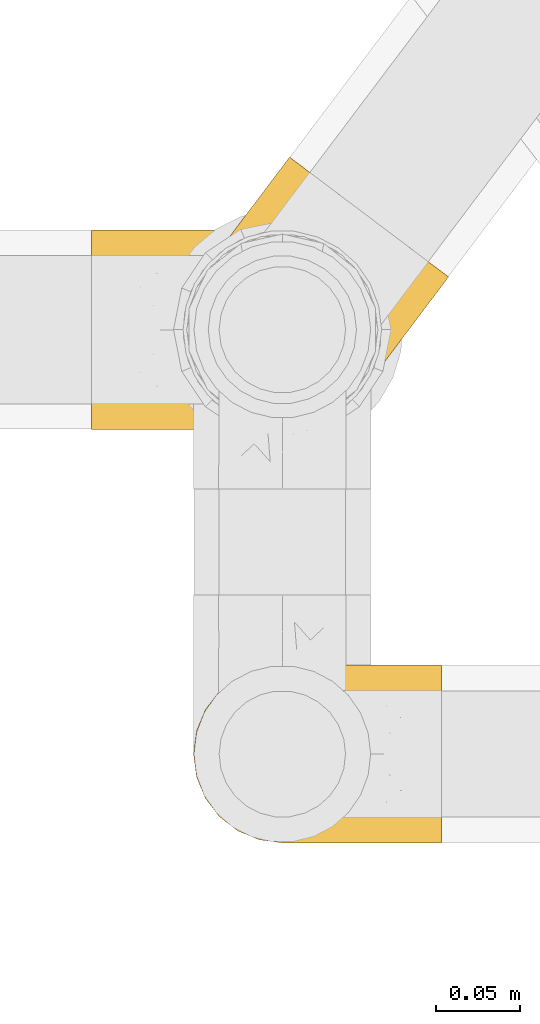
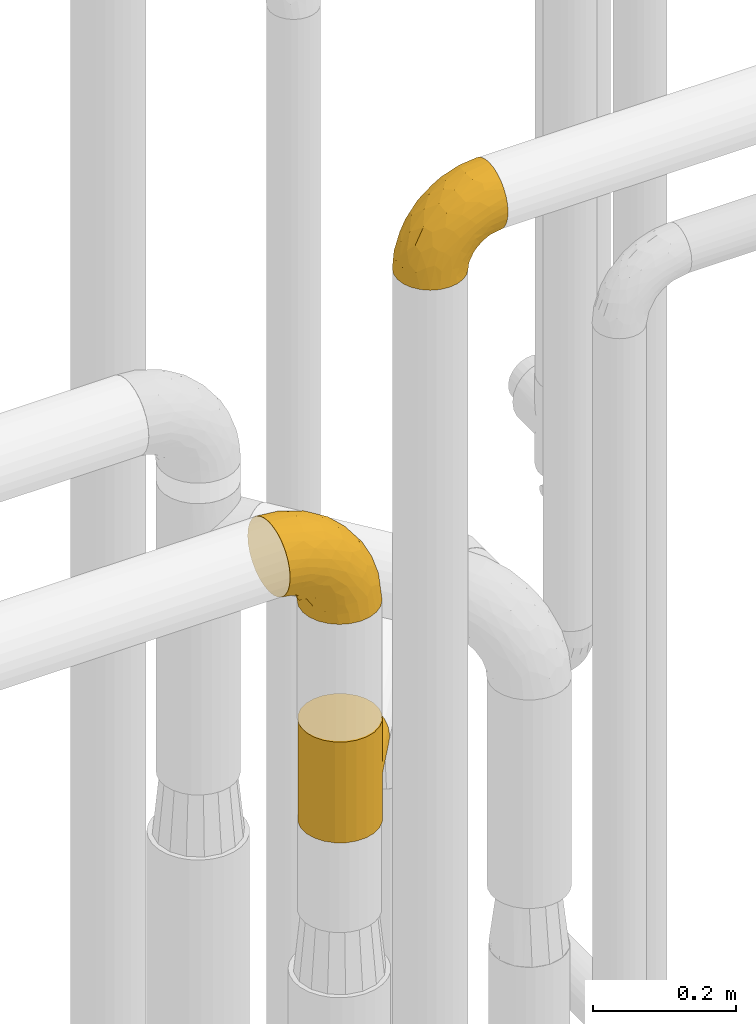
# One storey, part 378 of 827: 3 coverings.
"""IFC2X3 building model written with IfcOpenShell, lengths in millimetres."""

from ifc_helpers import new_model, entity, si_unit, converted_unit, derived_unit, direction, frame, origin, place, context, subcontext, project, spatial, faceted_brep, element, save


model = new_model("IFC2X3")

# Units and contexts
model_context = context("Model", 3, precision=0.01, world=origin(), true_north=direction((6.12303176911189e-17, 1.0)))
body_context = subcontext(model_context, "Body", "Model", "MODEL_VIEW")
ifc_project = project(units=[si_unit("LENGTHUNIT", "METRE", prefix="MILLI"), si_unit("AREAUNIT", "SQUARE_METRE"), si_unit("VOLUMEUNIT", "CUBIC_METRE"), converted_unit("PLANEANGLEUNIT", "DEGREE", entity("IfcRatioMeasure", 0.0174532925199433), si_unit("PLANEANGLEUNIT", "RADIAN"), dimensions=[0, 0, 0, 0, 0, 0, 0]), si_unit("MASSUNIT", "GRAM", prefix="KILO"), derived_unit("MASSDENSITYUNIT", [(si_unit("MASSUNIT", "GRAM", prefix="KILO"), 1), (si_unit("LENGTHUNIT", "METRE"), -3)]), derived_unit("MOMENTOFINERTIAUNIT", [(si_unit("LENGTHUNIT", "METRE"), 4)]), si_unit("TIMEUNIT", "SECOND"), si_unit("FREQUENCYUNIT", "HERTZ"), si_unit("THERMODYNAMICTEMPERATUREUNIT", "DEGREE_CELSIUS"), derived_unit("THERMALTRANSMITTANCEUNIT", [(si_unit("MASSUNIT", "GRAM", prefix="KILO"), 1), (si_unit("THERMODYNAMICTEMPERATUREUNIT", "KELVIN"), -1), (si_unit("TIMEUNIT", "SECOND"), -3)]), derived_unit("VOLUMETRICFLOWRATEUNIT", [(si_unit("LENGTHUNIT", "METRE"), 3), (si_unit("TIMEUNIT", "SECOND"), -1)]), derived_unit("MASSFLOWRATEUNIT", [(si_unit("MASSUNIT", "GRAM", prefix="KILO"), 1), (si_unit("TIMEUNIT", "SECOND"), -1)]), derived_unit("ROTATIONALFREQUENCYUNIT", [(si_unit("TIMEUNIT", "SECOND"), -1)]), si_unit("ELECTRICCURRENTUNIT", "AMPERE"), si_unit("ELECTRICVOLTAGEUNIT", "VOLT"), si_unit("POWERUNIT", "WATT"), si_unit("FORCEUNIT", "NEWTON", prefix="KILO"), si_unit("ILLUMINANCEUNIT", "LUX"), si_unit("LUMINOUSFLUXUNIT", "LUMEN"), si_unit("LUMINOUSINTENSITYUNIT", "CANDELA"), derived_unit("USERDEFINED", [(si_unit("MASSUNIT", "GRAM", prefix="KILO"), -1), (si_unit("LENGTHUNIT", "METRE"), -2), (si_unit("TIMEUNIT", "SECOND"), 3), (si_unit("LUMINOUSFLUXUNIT", "LUMEN"), 1)]), derived_unit("LINEARVELOCITYUNIT", [(si_unit("LENGTHUNIT", "METRE"), 1), (si_unit("TIMEUNIT", "SECOND"), -1)]), si_unit("PRESSUREUNIT", "PASCAL"), derived_unit("USERDEFINED", [(si_unit("LENGTHUNIT", "METRE"), -2), (si_unit("MASSUNIT", "GRAM", prefix="KILO"), 1), (si_unit("TIMEUNIT", "SECOND"), -2)]), derived_unit("LINEARFORCEUNIT", [(si_unit("MASSUNIT", "GRAM", prefix="KILO"), 1), (si_unit("LENGTHUNIT", "METRE"), 1), (si_unit("TIMEUNIT", "SECOND"), -2), (si_unit("LENGTHUNIT", "METRE"), -1)]), derived_unit("PLANARFORCEUNIT", [(si_unit("MASSUNIT", "GRAM", prefix="KILO"), 1), (si_unit("LENGTHUNIT", "METRE"), 1), (si_unit("TIMEUNIT", "SECOND"), -2), (si_unit("LENGTHUNIT", "METRE"), -2)])], contexts=[model_context])

# Site, building, storey
site_placement = place(None, origin())
site = spatial("IfcSite", under=ifc_project, at=site_placement, CompositionType="ELEMENT")
building_placement = place(site_placement, origin())
building = spatial("IfcBuilding", under=site, at=building_placement, CompositionType="ELEMENT")
storey_placement = place(building_placement, frame((0.0, 0.0, 28200.0)))
storey = spatial("IfcBuildingStorey", under=building, at=storey_placement, Name="08", CompositionType="ELEMENT", Elevation=28200.0)

# Coverings
covering_1_placement = place(storey_placement, frame((45438.63, 13582.19, 3103.45)))
element("IfcCovering", 1, at=covering_1_placement, inside=storey, Name=":ADSK_", ObjectType=":ADSK_", PredefinedType="INSULATION", context=body_context, shape_type="Brep", body=[
    faceted_brep([(149.65, 66.44, 148.32), (149.65, 54.65, 149.65), (149.65, 42.84, 148.31), (149.65, 31.62, 144.39), (149.65, 21.56, 138.06), (149.65, 13.16, 129.66), (149.65, 6.84, 119.6), (149.65, 2.92, 108.39), (149.65, 1.6, 96.6), (149.65, 2.93, 84.79), (149.65, 6.85, 73.57), (149.65, 13.18, 63.51), (149.65, 21.58, 55.11), (149.65, 31.64, 48.79), (149.65, 42.85, 44.87), (149.65, 54.65, 43.55), (149.65, 66.46, 44.88), (149.65, 77.67, 48.8), (149.65, 87.73, 55.13), (149.65, 96.13, 63.53), (149.65, 102.45, 73.59), (149.65, 106.37, 84.8), (149.65, 107.7, 96.6), (149.65, 106.36, 108.41), (149.65, 102.44, 119.62), (149.65, 96.11, 129.68), (149.65, 87.71, 138.08), (149.65, 77.65, 144.4), (105.89, 40.91, 1.6), (100.59, 28.12, 1.6), (92.16, 17.13, 1.6), (81.17, 8.7, 1.6), (68.38, 3.4, 1.6), (54.65, 1.6, 1.6), (40.91, 3.4, 1.6), (28.12, 8.7, 1.6), (17.13, 17.13, 1.6), (8.7, 28.12, 1.6), (3.4, 40.91, 1.6), (1.6, 54.65, 1.6), (3.4, 68.38, 1.6), (8.7, 81.17, 1.6), (17.13, 92.16, 1.6), (28.12, 100.59, 1.6), (40.91, 105.89, 1.6), (54.65, 107.7, 1.6), (68.38, 105.89, 1.6), (81.17, 100.59, 1.6), (92.16, 92.16, 1.6), (100.59, 81.17, 1.6), (105.89, 68.38, 1.6), (107.7, 54.65, 1.6), (14.05, 85.53, 27.97), (9.45, 73.42, 37.09), (22.36, 83.77, 58.27), (4.7, 64.22, 27.13), (6.64, 54.65, 39.91), (81.47, 96.72, 109.11), (56.83, 93.36, 94.41), (64.02, 84.47, 110.94), (34.04, 71.37, 89.69), (21.43, 54.65, 75.62), (44.96, 54.65, 106.28), (49.8, 103.47, 60.12), (35.43, 100.91, 41.41), (42.1, 99.1, 63.22), (43.59, 105.43, 32.05), (57.88, 106.79, 52.13), (91.8, 89.81, 123.27), (88.01, 79.59, 129.32), (115.65, 81.29, 138.3), (18.94, 74.01, 62.95), (12.83, 64.14, 55.89), (24.96, 94.75, 37.4), (111.33, 54.65, 144.6), (113.8, 70.74, 142.66), (60.89, 68.3, 117.85), (86.24, 66.05, 134.01), (65.84, 100.73, 89.25), (124.58, 106.78, 103.34), (121.36, 103.6, 113.52), (72.79, 107.7, 57.43), (66.04, 107.7, 44.19), (59.29, 107.7, 30.95), (73.26, 106.07, 77.98), (121.69, 90.59, 132.66), (109.82, 97.43, 121.52), (40.11, 84.51, 86.93), (36.57, 93.3, 68.4), (93.81, 107.7, 78.45), (83.3, 107.7, 67.94), (136.6, 107.7, 94.53), (120.29, 107.7, 91.95), (99.11, 106.79, 93.36), (107.05, 107.7, 85.2), (91.12, 103.47, 101.45), (75.62, 54.65, 129.81), (56.97, 107.7, 16.27), (126.65, 76.99, 42.46), (116.55, 84.28, 40.4), (120.09, 91.11, 49.71), (76.06, 106.26, 39.4), (83.69, 102.6, 31.26), (71.88, 106.08, 27.7), (66.92, 106.56, 16.7), (110.43, 105.36, 70.67), (121.31, 106.74, 81.69), (81.0, 101.59, 16.68), (113.32, 54.65, 22.57), (111.09, 54.65, 14.26), (109.14, 67.71, 17.68), (95.86, 91.36, 19.58), (99.07, 94.33, 33.49), (106.92, 87.1, 33.01), (131.39, 65.84, 40.69), (136.98, 54.65, 40.15), (128.67, 54.65, 37.93), (117.07, 68.92, 31.04), (96.39, 100.82, 45.29), (106.61, 79.83, 23.55), (103.72, 77.13, 11.36), (92.14, 105.9, 59.1), (107.13, 101.53, 57.42), (98.03, 106.72, 68.96), (88.38, 97.75, 20.38), (130.66, 103.08, 72.46), (135.45, 106.39, 83.66), (123.57, 98.1, 60.66), (137.75, 95.02, 61.01), (133.2, 86.9, 51.85), (138.8, 74.42, 46.07), (120.99, 54.65, 30.25), (84.53, 105.28, 46.65), (108.72, 92.87, 43.0), (95.86, 17.93, 19.58), (130.67, 6.22, 72.44), (109.13, 41.58, 17.67), (93.81, 1.6, 78.45), (98.02, 2.57, 68.97), (110.43, 3.94, 70.65), (131.4, 43.46, 40.69), (126.66, 32.32, 42.45), (117.08, 40.38, 31.04), (108.74, 16.44, 42.99), (96.31, 8.47, 45.18), (99.11, 15.01, 33.46), (123.58, 11.21, 60.64), (107.12, 7.78, 57.37), (72.79, 1.6, 57.43), (66.04, 1.6, 44.19), (76.07, 3.04, 39.35), (56.97, 1.6, 16.27), (66.92, 2.73, 16.7), (120.29, 1.6, 91.95), (107.05, 1.6, 85.2), (121.26, 2.55, 81.68), (84.46, 3.98, 46.68), (83.69, 6.69, 31.26), (81.0, 7.7, 16.68), (71.88, 3.21, 27.7), (137.76, 14.28, 60.99), (133.21, 22.42, 51.84), (116.58, 25.02, 40.41), (120.1, 18.18, 49.72), (138.81, 34.89, 46.06), (136.6, 1.6, 94.53), (103.72, 32.17, 11.35), (106.96, 22.23, 33.02), (135.44, 2.91, 83.65), (88.38, 11.54, 20.38), (83.3, 1.6, 67.94), (106.6, 29.46, 23.53), (92.12, 3.38, 59.12), (59.29, 1.6, 30.95), (22.36, 25.52, 58.27), (14.05, 23.76, 27.97), (24.96, 14.54, 37.4), (35.43, 8.38, 41.41), (4.71, 45.07, 27.21), (9.45, 35.87, 37.09), (11.79, 45.14, 53.2), (57.88, 2.5, 52.13), (124.57, 2.51, 103.34), (121.37, 5.68, 113.5), (91.12, 5.82, 101.45), (56.83, 15.93, 94.41), (81.48, 12.54, 109.08), (64.05, 24.81, 110.95), (99.11, 2.5, 93.36), (73.26, 3.22, 77.98), (43.59, 3.86, 32.05), (19.5, 35.85, 64.63), (91.8, 19.47, 123.25), (121.7, 18.68, 132.65), (88.04, 29.68, 129.32), (123.34, 27.95, 139.96), (60.89, 40.99, 117.85), (34.04, 37.92, 89.69), (109.85, 11.85, 121.51), (42.1, 10.19, 63.23), (65.78, 8.55, 89.17), (113.81, 38.53, 142.66), (36.57, 15.99, 68.4), (40.12, 24.79, 86.94), (49.8, 5.82, 60.12), (86.08, 40.56, 133.2)], [[[0, 1, 2, 3, 4, 5, 6, 7, 8, 9, 10, 11, 12, 13, 14, 15, 16, 17, 18, 19, 20, 21, 22, 23, 24, 25, 26, 27]], [[28, 29, 30, 31, 32, 33, 34, 35, 36, 37, 38, 39, 40, 41, 42, 43, 44, 45, 46, 47, 48, 49, 50, 51]], [[52, 53, 54]], [[55, 39, 56]], [[57, 58, 59]], [[60, 61, 62]], [[63, 64, 65]], [[66, 63, 67]], [[68, 69, 70]], [[53, 71, 54]], [[41, 40, 53]], [[53, 72, 71]], [[73, 42, 52]], [[42, 41, 52]], [[74, 0, 75]], [[69, 76, 77]], [[43, 73, 64]], [[45, 44, 66]], [[57, 78, 58]], [[23, 79, 80]], [[67, 81, 82, 83]], [[67, 84, 81]], [[24, 23, 80]], [[25, 85, 26]], [[86, 85, 25]], [[42, 73, 43]], [[0, 27, 75]], [[25, 24, 86]], [[70, 26, 85]], [[0, 74, 1]], [[68, 85, 86]], [[66, 64, 63]], [[60, 59, 87]], [[54, 87, 88]], [[76, 60, 62]], [[84, 89, 90, 81]], [[79, 22, 91, 92]], [[77, 74, 75]], [[93, 92, 94, 89]], [[80, 86, 24]], [[40, 55, 53]], [[76, 59, 60]], [[93, 84, 95]], [[76, 62, 96]], [[55, 72, 53]], [[70, 27, 26]], [[75, 70, 69]], [[78, 84, 63]], [[93, 79, 92]], [[95, 86, 80]], [[77, 76, 96]], [[59, 69, 68]], [[57, 68, 86]], [[68, 57, 59]], [[59, 58, 87]], [[76, 69, 59]], [[88, 87, 58]], [[87, 54, 71]], [[86, 95, 57]], [[78, 57, 95]], [[84, 78, 95]], [[78, 63, 65]], [[58, 78, 65]], [[54, 88, 73]], [[84, 93, 89]], [[79, 95, 80]], [[79, 93, 95]], [[22, 79, 23]], [[66, 83, 97, 45]], [[84, 67, 63]], [[83, 66, 67]], [[64, 44, 43]], [[64, 66, 44]], [[65, 73, 88]], [[53, 52, 41]], [[73, 52, 54]], [[73, 65, 64]], [[65, 88, 58]], [[39, 55, 40]], [[72, 55, 56]], [[56, 61, 72]], [[60, 72, 61]], [[72, 60, 71]], [[87, 71, 60]], [[27, 70, 75]], [[68, 70, 85]], [[74, 77, 96]], [[69, 77, 75]], [[98, 99, 100]], [[46, 45, 97]], [[101, 102, 103]], [[103, 104, 83]], [[105, 94, 106]], [[107, 103, 102]], [[108, 109, 51, 110]], [[111, 112, 113]], [[114, 115, 116]], [[47, 104, 107]], [[110, 117, 108]], [[49, 48, 111]], [[102, 118, 112]], [[119, 120, 111]], [[50, 49, 120]], [[121, 122, 118]], [[105, 123, 89]], [[124, 48, 107]], [[20, 19, 125]], [[121, 81, 90]], [[117, 119, 99]], [[21, 20, 126]], [[22, 21, 91]], [[105, 125, 127]], [[110, 51, 50]], [[19, 128, 125]], [[16, 15, 115]], [[129, 98, 100]], [[126, 91, 21]], [[128, 129, 127]], [[122, 123, 105]], [[114, 117, 98]], [[17, 16, 130]], [[18, 128, 19]], [[129, 18, 17]], [[125, 106, 126]], [[115, 114, 16]], [[130, 129, 17]], [[114, 98, 130]], [[117, 116, 131, 108]], [[99, 119, 113]], [[122, 121, 123]], [[92, 126, 106]], [[105, 127, 122]], [[132, 121, 118]], [[114, 130, 16]], [[129, 130, 98]], [[50, 120, 110]], [[129, 128, 18]], [[125, 128, 127]], [[125, 126, 20]], [[91, 126, 92]], [[105, 89, 94]], [[105, 106, 125]], [[94, 92, 106]], [[100, 122, 127]], [[118, 122, 133]], [[112, 118, 133]], [[132, 118, 102]], [[132, 102, 101]], [[81, 121, 132]], [[82, 103, 83]], [[132, 101, 81]], [[104, 47, 46]], [[124, 107, 102]], [[48, 47, 107]], [[113, 112, 133]], [[112, 111, 124]], [[99, 113, 133]], [[111, 113, 119]], [[99, 133, 100]], [[117, 99, 98]], [[122, 100, 133]], [[127, 129, 100]], [[103, 82, 101]], [[81, 101, 82]], [[112, 124, 102]], [[48, 124, 111]], [[104, 103, 107]], [[46, 97, 104]], [[111, 120, 49]], [[83, 104, 97]], [[110, 120, 119]], [[117, 110, 119]], [[116, 117, 114]], [[123, 90, 89]], [[90, 123, 121]], [[30, 29, 134]], [[11, 10, 135]], [[51, 109, 108, 136]], [[137, 138, 139]], [[140, 141, 142]], [[143, 144, 145]], [[146, 139, 147]], [[148, 149, 150]], [[151, 32, 152]], [[153, 154, 155]], [[156, 150, 157]], [[158, 157, 159]], [[108, 142, 136]], [[31, 158, 152]], [[160, 161, 12]], [[162, 163, 143]], [[140, 142, 116]], [[142, 141, 162]], [[14, 164, 140]], [[14, 140, 115]], [[9, 8, 165]], [[160, 12, 11]], [[141, 164, 161]], [[13, 12, 161]], [[14, 115, 15]], [[28, 166, 29]], [[135, 139, 146]], [[141, 163, 162]], [[135, 146, 160]], [[143, 167, 162]], [[29, 166, 134]], [[116, 142, 108, 131]], [[165, 153, 168]], [[10, 9, 168]], [[168, 135, 10]], [[138, 147, 139]], [[158, 169, 157]], [[14, 13, 164]], [[116, 115, 140]], [[145, 167, 143]], [[135, 160, 11]], [[168, 153, 155]], [[138, 137, 170]], [[157, 144, 156]], [[147, 144, 143]], [[161, 164, 13]], [[140, 164, 141]], [[142, 171, 136]], [[136, 171, 166]], [[161, 160, 146]], [[165, 168, 9]], [[155, 139, 135]], [[139, 154, 137]], [[168, 155, 135]], [[139, 155, 154]], [[144, 147, 172]], [[163, 147, 143]], [[156, 144, 172]], [[157, 169, 145]], [[172, 148, 156]], [[173, 159, 149]], [[159, 157, 150]], [[152, 159, 173]], [[159, 152, 158]], [[31, 30, 158]], [[169, 30, 134]], [[157, 145, 144]], [[167, 134, 171]], [[134, 167, 145]], [[171, 142, 162]], [[162, 167, 171]], [[163, 141, 161]], [[161, 146, 163]], [[147, 163, 146]], [[148, 150, 156]], [[149, 159, 150]], [[30, 169, 158]], [[145, 169, 134]], [[151, 33, 32]], [[31, 152, 32]], [[152, 173, 151]], [[28, 51, 136]], [[134, 166, 171]], [[28, 136, 166]], [[138, 170, 172]], [[147, 138, 172]], [[148, 172, 170]], [[174, 175, 176]], [[35, 34, 177]], [[178, 179, 180]], [[181, 173, 149, 148]], [[182, 183, 184]], [[185, 186, 187]], [[188, 189, 137]], [[190, 33, 151, 173]], [[191, 179, 174]], [[34, 190, 177]], [[39, 38, 178]], [[192, 193, 194]], [[4, 3, 195]], [[175, 179, 37]], [[38, 37, 179]], [[35, 176, 36]], [[196, 62, 197]], [[181, 190, 173]], [[37, 36, 175]], [[183, 6, 198]], [[189, 148, 170, 137]], [[185, 199, 200]], [[3, 2, 201]], [[202, 185, 203]], [[8, 7, 182]], [[200, 184, 186]], [[183, 7, 6]], [[181, 189, 204]], [[200, 189, 184]], [[5, 198, 6]], [[187, 203, 185]], [[195, 3, 201]], [[205, 196, 194]], [[62, 61, 197]], [[186, 198, 192]], [[180, 179, 191]], [[2, 1, 74]], [[198, 193, 192]], [[193, 5, 4]], [[194, 193, 195]], [[2, 74, 201]], [[5, 193, 198]], [[205, 74, 96]], [[188, 137, 154, 153]], [[62, 196, 96]], [[56, 178, 180]], [[198, 184, 183]], [[184, 188, 182]], [[203, 197, 191]], [[205, 194, 201]], [[187, 192, 194]], [[192, 187, 186]], [[194, 196, 187]], [[197, 187, 196]], [[197, 203, 187]], [[202, 174, 176]], [[200, 186, 185]], [[184, 198, 186]], [[199, 185, 202]], [[189, 200, 204]], [[174, 202, 203]], [[176, 177, 199]], [[189, 181, 148]], [[190, 181, 204]], [[190, 204, 177]], [[190, 34, 33]], [[188, 153, 182]], [[189, 188, 184]], [[182, 153, 165, 8]], [[183, 182, 7]], [[199, 177, 204]], [[35, 177, 176]], [[176, 175, 36]], [[179, 175, 174]], [[200, 199, 204]], [[176, 199, 202]], [[203, 191, 174]], [[180, 197, 61]], [[197, 180, 191]], [[61, 56, 180]], [[39, 178, 56]], [[38, 179, 178]], [[194, 195, 201]], [[4, 195, 193]], [[74, 205, 201]], [[96, 196, 205]]]),
])
covering_2_placement = place(storey_placement, frame((45432.68, 13828.18, 2014.0)))
element("IfcCovering", 2, at=covering_2_placement, inside=storey, Name=":ADSK_", ObjectType=":ADSK_", PredefinedType="INSULATION", context=body_context, shape_type="Brep", body=[
    faceted_brep([(86.76, 113.99, 27.62), (89.63, 111.9, 0.0), (82.87, 115.72, 0.0), (76.55, 117.87, 30.66), (75.36, 117.67, 0.0), (67.85, 119.61, 0.0), (56.59, 119.92, 41.04), (52.33, 119.47, 0.0), (96.38, 108.08, 26.55), (96.38, 108.08, 0.0), (96.38, 108.08, 172.0), (96.38, 108.08, 145.45), (89.63, 111.9, 172.0), (66.36, 119.77, 35.28), (47.44, 118.58, 47.62), (39.01, 115.99, 54.76), (37.37, 115.33, 0.0), (31.34, 112.35, 62.28), (24.0, 107.45, 0.0), (18.37, 102.45, 77.99), (13.12, 96.38, 0.0), (24.46, 107.8, 70.06), (13.12, 96.38, 86.0), (18.37, 102.45, 94.01), (13.12, 96.38, 172.0), (112.47, 31.54, 77.99), (108.08, 24.82, 0.0), (115.72, 38.33, 0.0), (119.61, 53.36, 0.0), (118.41, 46.73, 62.29), (119.96, 63.92, 47.63), (119.47, 68.88, 0.0), (119.8, 55.11, 54.76), (108.08, 24.82, 86.0), (112.47, 31.54, 94.01), (108.08, 24.82, 172.0), (115.93, 38.86, 70.06), (118.73, 73.09, 41.05), (115.33, 83.83, 0.0), (111.26, 91.71, 30.67), (111.39, 90.52, 0.0), (107.45, 97.2, 0.0), (101.91, 102.64, 0.0), (101.91, 102.64, 172.0), (115.9, 82.44, 35.28), (104.71, 100.46, 27.62), (5.88, 37.37, 172.0), (13.75, 24.0, 172.0), (24.82, 13.12, 172.0), (38.33, 5.48, 172.0), (53.36, 1.6, 172.0), (68.88, 1.73, 172.0), (83.83, 5.88, 172.0), (97.2, 13.75, 172.0), (115.72, 38.33, 172.0), (119.61, 53.36, 172.0), (119.47, 68.88, 172.0), (115.33, 83.83, 172.0), (111.39, 90.52, 172.0), (107.45, 97.2, 172.0), (82.87, 115.72, 172.0), (75.36, 117.67, 172.0), (67.85, 119.61, 172.0), (52.33, 119.47, 172.0), (37.37, 115.33, 172.0), (24.0, 107.45, 172.0), (5.48, 82.87, 172.0), (1.6, 67.85, 172.0), (1.73, 52.33, 172.0), (97.2, 13.75, 0.0), (83.83, 5.88, 0.0), (68.88, 1.73, 0.0), (53.36, 1.6, 0.0), (38.33, 5.48, 0.0), (24.82, 13.12, 0.0), (13.75, 24.0, 0.0), (5.88, 37.37, 0.0), (1.73, 52.33, 0.0), (1.6, 67.85, 0.0), (5.48, 82.87, 0.0), (115.93, 38.86, 101.94), (118.41, 46.73, 109.71), (119.8, 55.11, 117.24), (119.96, 63.92, 124.37), (118.73, 73.09, 130.95), (115.9, 82.44, 136.72), (111.26, 91.71, 141.33), (104.71, 100.46, 144.38), (86.76, 113.99, 144.38), (76.55, 117.87, 141.34), (66.36, 119.77, 136.72), (56.59, 119.92, 130.96), (47.44, 118.58, 124.38), (31.34, 112.35, 109.72), (24.46, 107.8, 101.94), (39.01, 115.99, 117.24), (159.84, 93.51, 86.0), (158.22, 94.73, 70.61), (153.48, 98.3, 56.27), (145.93, 103.99, 43.96), (136.1, 111.4, 34.51), (130.37, 115.71, 31.55), (124.65, 120.02, 28.58), (118.5, 124.65, 27.56), (112.36, 129.28, 26.55), (106.21, 133.91, 27.56), (100.07, 138.54, 28.58), (94.34, 142.86, 31.55), (88.62, 147.17, 34.51), (78.79, 154.58, 43.96), (71.24, 160.27, 56.27), (66.5, 163.84, 70.61), (64.88, 165.06, 86.0), (66.5, 163.84, 101.39), (71.24, 160.27, 115.72), (78.79, 154.58, 128.04), (88.62, 147.17, 137.49), (94.34, 142.86, 140.45), (100.07, 138.54, 143.42), (106.21, 133.91, 144.44), (112.36, 129.28, 145.45), (118.5, 124.65, 144.44), (124.65, 120.02, 143.42), (130.37, 115.71, 140.45), (136.1, 111.4, 137.49), (145.93, 103.99, 128.04), (153.48, 98.3, 115.72), (158.22, 94.73, 101.39)], [[[0, 1, 2]], [[3, 2, 4, 5]], [[6, 5, 7]], [[8, 1, 0]], [[8, 9, 1]], [[10, 11, 12]], [[13, 3, 5]], [[6, 13, 5]], [[0, 2, 3]], [[7, 14, 6]], [[15, 14, 16]], [[16, 14, 7]], [[17, 16, 18]], [[19, 18, 20]], [[17, 15, 16]], [[19, 21, 18]], [[22, 19, 20]], [[23, 22, 24]], [[17, 18, 21]], [[25, 26, 27]], [[27, 28, 29]], [[30, 28, 31]], [[30, 32, 28]], [[25, 33, 26]], [[33, 34, 35]], [[29, 36, 27]], [[32, 29, 28]], [[25, 27, 36]], [[37, 31, 38]], [[39, 38, 40, 41]], [[42, 9, 8]], [[43, 11, 10]], [[44, 37, 38]], [[45, 39, 41]], [[45, 42, 8]], [[45, 41, 42]], [[44, 38, 39]], [[31, 37, 30]], [[46, 47, 48, 49, 50, 51, 52, 53, 35, 54, 55, 56, 57, 58, 59, 43, 10, 12, 60, 61, 62, 63, 64, 65, 24, 66, 67, 68]], [[26, 69, 70, 71, 72, 73, 74, 75, 76, 77, 78, 79, 20, 18, 16, 7, 5, 4, 2, 1, 9, 42, 41, 40, 38, 31, 28, 27]], [[72, 71, 51, 50]], [[48, 74, 73, 49]], [[49, 73, 72, 50]], [[52, 70, 69, 53]], [[26, 33, 35, 53, 69]], [[51, 71, 70, 52]], [[80, 81, 54]], [[34, 80, 54]], [[35, 34, 54]], [[55, 82, 83]], [[55, 54, 81]], [[55, 83, 56]], [[82, 55, 81]], [[84, 85, 57]], [[86, 59, 58, 57]], [[86, 87, 59]], [[11, 43, 87]], [[85, 86, 57]], [[56, 84, 57]], [[87, 43, 59]], [[84, 56, 83]], [[88, 89, 60]], [[88, 60, 12]], [[90, 91, 62]], [[89, 62, 61, 60]], [[89, 90, 62]], [[88, 12, 11]], [[91, 63, 62]], [[91, 92, 63]], [[93, 94, 65]], [[94, 23, 65]], [[92, 95, 64]], [[93, 64, 95]], [[93, 65, 64]], [[23, 24, 65]], [[92, 64, 63]], [[22, 20, 79, 66, 24]], [[66, 79, 78, 67]], [[78, 77, 68, 67]], [[68, 77, 76, 46]], [[46, 76, 75, 47]], [[47, 75, 74, 48]], [[96, 97, 98, 99, 100, 101, 102, 103, 104, 105, 106, 107, 108, 109, 110, 111, 112, 113, 114, 115, 116, 117, 118, 119, 120, 121, 122, 123, 124, 125, 126, 127]], [[103, 102, 45]], [[100, 99, 37]], [[101, 100, 39, 102]], [[8, 103, 45]], [[8, 104, 103]], [[44, 39, 100]], [[37, 44, 100]], [[45, 102, 39]], [[99, 30, 37]], [[32, 30, 98]], [[98, 30, 99]], [[29, 98, 97]], [[25, 97, 96]], [[29, 32, 98]], [[25, 36, 97]], [[33, 25, 96]], [[29, 97, 36]], [[34, 96, 127]], [[127, 126, 81]], [[83, 126, 125]], [[83, 82, 126]], [[34, 33, 96]], [[81, 80, 127]], [[82, 81, 126]], [[34, 127, 80]], [[84, 125, 124]], [[86, 124, 123, 122]], [[121, 120, 11]], [[85, 84, 124]], [[87, 86, 122]], [[87, 121, 11]], [[87, 122, 121]], [[85, 124, 86]], [[125, 84, 83]], [[88, 119, 118]], [[89, 118, 117, 116]], [[91, 116, 115]], [[11, 119, 88]], [[11, 120, 119]], [[90, 89, 116]], [[91, 90, 116]], [[88, 118, 89]], [[115, 92, 91]], [[95, 92, 114]], [[114, 92, 115]], [[93, 114, 113]], [[23, 113, 112]], [[93, 95, 114]], [[23, 94, 113]], [[22, 23, 112]], [[93, 113, 94]], [[19, 112, 111]], [[111, 110, 17]], [[14, 110, 109]], [[14, 15, 110]], [[19, 22, 112]], [[17, 21, 111]], [[15, 17, 110]], [[19, 111, 21]], [[6, 109, 108]], [[3, 108, 107, 106]], [[105, 104, 8]], [[13, 6, 108]], [[0, 3, 106]], [[0, 105, 8]], [[0, 106, 105]], [[13, 108, 3]], [[109, 6, 14]]]),
])
covering_3_placement = place(storey_placement, frame((45377.68, 13829.13, 2384.4)))
element("IfcCovering", 3, at=covering_3_placement, inside=storey, Name=":ADSK_", ObjectType=":ADSK_", PredefinedType="INSULATION", context=body_context, shape_type="Brep", body=[
    faceted_brep([(1.6, 3.09, 128.83), (1.6, 7.48, 141.39), (1.6, 14.57, 152.67), (1.6, 23.99, 162.08), (1.6, 35.26, 169.16), (1.6, 47.83, 173.56), (1.6, 61.05, 175.05), (1.6, 74.28, 173.55), (1.6, 86.84, 169.16), (1.6, 98.12, 162.07), (1.6, 107.53, 152.66), (1.6, 114.61, 141.38), (1.6, 119.01, 128.81), (1.6, 120.5, 115.6), (1.6, 119.0, 102.36), (1.6, 114.61, 89.8), (1.6, 107.52, 78.52), (1.6, 98.11, 69.11), (1.6, 86.83, 62.03), (1.6, 74.26, 57.63), (1.6, 61.05, 56.15), (1.6, 47.81, 57.64), (1.6, 35.25, 62.03), (1.6, 23.97, 69.12), (1.6, 14.56, 78.54), (1.6, 7.48, 89.81), (1.6, 3.08, 102.38), (1.6, 1.6, 115.6), (58.17, 76.43, 1.6), (64.11, 90.77, 1.6), (73.56, 103.08, 1.6), (85.87, 112.53, 1.6), (100.21, 118.47, 1.6), (115.6, 120.5, 1.6), (130.98, 118.47, 1.6), (145.32, 112.53, 1.6), (157.63, 103.08, 1.6), (167.08, 90.77, 1.6), (173.02, 76.43, 1.6), (175.05, 61.05, 1.6), (173.02, 45.66, 1.6), (167.08, 31.32, 1.6), (157.63, 19.01, 1.6), (145.32, 9.56, 1.6), (130.98, 3.62, 1.6), (115.6, 1.6, 1.6), (100.21, 3.62, 1.6), (85.87, 9.56, 1.6), (73.56, 19.01, 1.6), (64.11, 31.32, 1.6), (58.17, 45.66, 1.6), (56.15, 61.05, 1.6), (160.93, 26.35, 32.35), (165.97, 39.92, 43.24), (151.16, 28.21, 67.79), (169.95, 50.29, 39.06), (169.14, 61.05, 46.49), (47.74, 12.95, 143.21), (81.62, 13.44, 128.0), (69.65, 21.39, 144.51), (137.09, 42.15, 104.87), (151.81, 61.05, 88.32), (124.24, 61.05, 124.24), (120.32, 6.39, 70.72), (136.76, 9.17, 48.42), (129.05, 11.39, 74.22), (127.83, 4.16, 37.66), (111.19, 2.62, 61.68), (73.49, 32.88, 151.61), (40.92, 31.08, 162.2), (154.8, 39.09, 73.52), (161.22, 50.35, 66.93), (148.51, 15.99, 43.54), (46.49, 61.05, 169.14), (43.55, 42.92, 166.98), (105.65, 45.77, 137.86), (75.81, 48.29, 156.83), (102.22, 9.1, 103.08), (111.05, 17.8, 111.05), (31.64, 2.63, 122.98), (61.68, 2.62, 111.19), (70.72, 6.39, 120.32), (93.82, 1.6, 68.6), (101.92, 1.6, 52.71), (110.02, 1.6, 36.82), (88.32, 61.05, 151.81), (34.61, 6.12, 134.29), (34.27, 20.66, 155.8), (130.32, 27.95, 102.22), (101.6, 27.51, 130.43), (135.16, 18.02, 80.3), (92.65, 3.46, 92.65), (68.6, 1.6, 93.82), (81.21, 1.6, 81.21), (16.21, 1.6, 113.28), (36.82, 1.6, 110.02), (52.71, 1.6, 101.92), (113.28, 1.6, 16.21), (49.51, 4.42, 84.67), (24.29, 7.1, 87.66), (33.37, 12.91, 74.04), (97.47, 3.83, 21.09), (92.13, 4.22, 35.03), (65.64, 10.89, 52.93), (63.0, 18.68, 39.76), (72.44, 13.52, 34.91), (54.52, 9.33, 67.69), (38.38, 46.44, 44.31), (46.09, 32.11, 44.87), (30.11, 36.58, 54.18), (22.47, 61.05, 51.99), (22.86, 48.22, 53.35), (82.06, 10.83, 18.29), (68.74, 20.4, 23.44), (56.57, 33.35, 28.92), (60.39, 36.09, 13.79), (55.21, 47.57, 18.1), (47.46, 51.17, 32.62), (51.99, 61.05, 22.47), (19.27, 3.13, 100.59), (66.98, 3.08, 78.3), (75.5, 4.42, 62.67), (15.03, 39.16, 58.76), (21.65, 25.38, 64.93), (38.96, 25.84, 56.12), (16.17, 16.08, 75.28), (36.61, 2.83, 97.34), (42.47, 16.53, 64.0), (40.17, 61.05, 40.17), (81.33, 7.67, 38.41), (89.72, 2.95, 51.71), (52.09, 19.15, 52.67), (62.98, 103.39, 39.74), (52.08, 102.93, 52.66), (65.65, 111.19, 52.9), (89.82, 116.28, 27.75), (89.72, 119.14, 51.71), (97.2, 119.37, 38.57), (38.35, 75.63, 44.33), (54.51, 112.75, 67.68), (68.6, 120.5, 93.82), (81.21, 120.5, 81.21), (66.99, 119.01, 78.3), (55.21, 74.51, 18.1), (24.29, 114.98, 87.65), (60.39, 86.0, 13.78), (16.17, 106.0, 75.27), (21.63, 96.69, 64.92), (97.47, 118.26, 21.09), (113.28, 120.5, 16.21), (75.5, 117.67, 62.67), (68.74, 101.69, 23.43), (47.46, 70.94, 32.63), (82.06, 111.26, 18.29), (42.47, 105.56, 63.99), (38.93, 96.25, 56.13), (22.84, 73.86, 53.35), (36.82, 120.5, 110.02), (52.71, 120.5, 101.92), (36.62, 119.26, 97.32), (16.21, 120.5, 113.28), (30.08, 85.49, 54.19), (15.02, 82.92, 58.76), (46.08, 89.98, 44.88), (56.57, 88.74, 28.91), (101.92, 120.5, 52.71), (49.52, 117.67, 84.65), (33.36, 109.17, 74.03), (19.28, 118.95, 100.57), (72.43, 108.57, 34.93), (93.82, 120.5, 68.6), (110.02, 120.5, 36.82), (81.33, 114.42, 38.41), (151.16, 93.88, 67.79), (160.93, 95.74, 32.35), (148.51, 106.1, 43.54), (136.76, 112.92, 48.42), (169.95, 71.8, 39.06), (165.97, 82.17, 43.24), (161.22, 71.74, 66.93), (111.19, 119.47, 61.68), (70.72, 115.7, 120.32), (31.66, 119.46, 122.97), (34.61, 115.98, 134.28), (111.05, 104.29, 111.05), (81.57, 108.66, 128.03), (101.58, 94.59, 130.43), (61.68, 119.47, 111.19), (92.65, 118.63, 92.65), (127.83, 117.93, 37.66), (154.8, 83.0, 73.52), (69.65, 100.71, 144.5), (34.27, 101.44, 155.79), (73.47, 89.22, 151.61), (32.52, 91.03, 164.01), (105.65, 76.32, 137.86), (137.09, 79.94, 104.87), (47.72, 109.15, 143.2), (129.05, 110.7, 74.22), (102.2, 112.98, 103.12), (43.54, 79.18, 166.97), (135.17, 104.06, 80.3), (130.32, 94.14, 102.23), (76.08, 77.09, 155.79), (120.32, 115.7, 70.72)], [[[0, 1, 2, 3, 4, 5, 6, 7, 8, 9, 10, 11, 12, 13, 14, 15, 16, 17, 18, 19, 20, 21, 22, 23, 24, 25, 26, 27]], [[28, 29, 30, 31, 32, 33, 34, 35, 36, 37, 38, 39, 40, 41, 42, 43, 44, 45, 46, 47, 48, 49, 50, 51]], [[52, 53, 54]], [[55, 39, 56]], [[57, 58, 59]], [[60, 61, 62]], [[63, 64, 65]], [[66, 63, 67]], [[59, 68, 69]], [[53, 70, 54]], [[41, 40, 53]], [[53, 71, 70]], [[72, 42, 52]], [[42, 41, 52]], [[73, 5, 74]], [[68, 75, 76]], [[43, 72, 64]], [[45, 44, 66]], [[58, 77, 78]], [[79, 80, 81]], [[67, 82, 83, 84]], [[75, 62, 85]], [[1, 0, 86]], [[2, 87, 3]], [[57, 87, 2]], [[42, 72, 43]], [[5, 4, 74]], [[2, 1, 57]], [[69, 3, 87]], [[5, 73, 6]], [[59, 87, 57]], [[66, 64, 63]], [[88, 89, 78]], [[54, 88, 90]], [[75, 60, 62]], [[91, 92, 93, 82]], [[79, 27, 94, 95]], [[76, 73, 74]], [[80, 95, 96, 92]], [[57, 1, 86]], [[56, 71, 55]], [[77, 91, 63]], [[80, 91, 81]], [[67, 91, 82]], [[71, 56, 61]], [[69, 4, 3]], [[74, 69, 68]], [[75, 89, 60]], [[80, 79, 95]], [[81, 57, 86]], [[76, 75, 85]], [[89, 68, 59]], [[58, 57, 81]], [[59, 58, 89]], [[90, 88, 78]], [[75, 68, 89]], [[70, 88, 54]], [[60, 89, 88]], [[77, 58, 81]], [[89, 58, 78]], [[91, 77, 81]], [[77, 63, 65]], [[78, 77, 65]], [[54, 90, 72]], [[91, 80, 92]], [[79, 81, 86]], [[86, 0, 79]], [[27, 79, 0]], [[66, 84, 97, 45]], [[91, 67, 63]], [[84, 66, 67]], [[64, 44, 43]], [[64, 66, 44]], [[65, 72, 90]], [[53, 52, 41]], [[72, 52, 54]], [[72, 65, 64]], [[65, 90, 78]], [[60, 71, 61]], [[55, 71, 53]], [[71, 60, 70]], [[88, 70, 60]], [[53, 40, 55]], [[39, 55, 40]], [[4, 69, 74]], [[59, 69, 87]], [[73, 76, 85]], [[68, 76, 74]], [[98, 99, 100]], [[84, 101, 97]], [[84, 83, 102]], [[97, 101, 46]], [[103, 104, 105]], [[47, 46, 101]], [[106, 98, 100]], [[107, 108, 109]], [[110, 107, 111]], [[112, 48, 47]], [[48, 113, 49]], [[113, 114, 115]], [[116, 51, 50]], [[115, 50, 49]], [[116, 117, 118]], [[119, 95, 94]], [[111, 107, 109]], [[93, 120, 121]], [[122, 123, 22]], [[121, 106, 103]], [[25, 24, 99]], [[114, 113, 104]], [[124, 109, 108]], [[25, 119, 26]], [[27, 26, 94]], [[112, 113, 48]], [[125, 123, 100]], [[24, 125, 99]], [[111, 20, 110]], [[109, 122, 111]], [[119, 94, 26]], [[99, 126, 119]], [[123, 124, 127]], [[117, 107, 128]], [[122, 22, 21]], [[129, 130, 121]], [[123, 23, 22]], [[92, 98, 120]], [[127, 106, 100]], [[23, 125, 24]], [[93, 121, 82]], [[119, 126, 95]], [[21, 20, 111]], [[123, 122, 109]], [[21, 111, 122]], [[107, 110, 128]], [[117, 128, 118]], [[107, 117, 108]], [[104, 108, 114]], [[124, 108, 131]], [[25, 99, 119]], [[96, 126, 98]], [[98, 92, 96]], [[123, 125, 23]], [[99, 125, 100]], [[103, 106, 131]], [[120, 106, 121]], [[83, 82, 130]], [[101, 102, 112]], [[130, 102, 83]], [[121, 130, 82]], [[102, 130, 129]], [[101, 112, 47]], [[112, 129, 105]], [[118, 51, 116]], [[108, 117, 114]], [[115, 116, 50]], [[114, 117, 116]], [[112, 102, 129]], [[102, 101, 84]], [[104, 103, 131]], [[129, 121, 103]], [[104, 131, 108]], [[105, 104, 113]], [[112, 105, 113]], [[103, 105, 129]], [[127, 124, 131]], [[123, 109, 124]], [[106, 127, 131]], [[123, 127, 100]], [[98, 126, 99]], [[95, 126, 96]], [[113, 115, 49]], [[116, 115, 114]], [[46, 45, 97]], [[92, 120, 93]], [[106, 120, 98]], [[132, 133, 134]], [[135, 136, 137]], [[110, 138, 128]], [[139, 134, 133]], [[140, 141, 142]], [[143, 51, 118]], [[16, 15, 144]], [[28, 145, 29]], [[146, 147, 17]], [[144, 146, 16]], [[31, 148, 32]], [[148, 149, 32]], [[139, 142, 150]], [[30, 29, 151]], [[152, 143, 118]], [[31, 30, 153]], [[139, 133, 154]], [[155, 154, 133]], [[110, 156, 138]], [[142, 141, 150]], [[20, 19, 156]], [[157, 158, 159]], [[14, 13, 160]], [[17, 16, 146]], [[161, 162, 147]], [[18, 162, 19]], [[152, 163, 164]], [[137, 136, 165]], [[144, 166, 167]], [[133, 163, 155]], [[144, 167, 146]], [[147, 18, 17]], [[29, 145, 151]], [[128, 138, 152]], [[160, 157, 168]], [[160, 168, 14]], [[14, 168, 15]], [[167, 166, 139]], [[151, 169, 153]], [[162, 156, 19]], [[141, 170, 150]], [[164, 163, 132]], [[147, 162, 18]], [[156, 162, 161]], [[156, 161, 138]], [[156, 110, 20]], [[163, 138, 161]], [[128, 152, 118]], [[155, 163, 161]], [[132, 163, 133]], [[159, 166, 144]], [[144, 15, 168]], [[166, 158, 140]], [[168, 159, 144]], [[147, 146, 167]], [[142, 139, 166]], [[134, 139, 150]], [[135, 31, 153]], [[136, 170, 165]], [[136, 150, 170]], [[148, 137, 171]], [[150, 136, 172]], [[151, 153, 30]], [[136, 135, 172]], [[163, 152, 138]], [[143, 28, 51]], [[152, 164, 143]], [[145, 143, 164]], [[171, 137, 165]], [[137, 148, 135]], [[31, 135, 148]], [[172, 135, 153]], [[150, 172, 134]], [[132, 169, 151]], [[169, 134, 172]], [[164, 132, 151]], [[134, 169, 132]], [[153, 169, 172]], [[161, 147, 155]], [[154, 147, 167]], [[147, 154, 155]], [[139, 154, 167]], [[157, 159, 168]], [[166, 159, 158]], [[143, 145, 28]], [[151, 145, 164]], [[149, 148, 171]], [[149, 33, 32]], [[140, 142, 166]], [[173, 174, 175]], [[35, 34, 176]], [[177, 178, 179]], [[180, 171, 165, 170]], [[181, 182, 183]], [[184, 185, 186]], [[187, 188, 140]], [[189, 33, 149, 171]], [[178, 190, 179]], [[34, 189, 176]], [[39, 38, 177]], [[191, 192, 193]], [[9, 8, 194]], [[174, 178, 37]], [[38, 37, 178]], [[35, 175, 36]], [[195, 62, 196]], [[180, 189, 171]], [[37, 36, 174]], [[183, 11, 197]], [[188, 170, 141, 140]], [[184, 198, 199]], [[8, 7, 200]], [[201, 184, 202]], [[13, 12, 182]], [[181, 185, 199]], [[183, 12, 11]], [[62, 195, 85]], [[202, 184, 186]], [[10, 197, 11]], [[199, 188, 181]], [[194, 8, 200]], [[203, 195, 193]], [[62, 61, 196]], [[197, 191, 185]], [[10, 192, 197]], [[7, 6, 73]], [[197, 192, 191]], [[192, 10, 9]], [[193, 192, 194]], [[7, 73, 200]], [[179, 61, 56]], [[203, 73, 85]], [[187, 140, 158, 157]], [[180, 188, 204]], [[179, 196, 61]], [[197, 181, 183]], [[181, 187, 182]], [[201, 173, 175]], [[203, 193, 200]], [[186, 191, 193]], [[197, 185, 181]], [[193, 195, 186]], [[196, 186, 195]], [[186, 196, 202]], [[190, 202, 196]], [[186, 185, 191]], [[199, 185, 184]], [[198, 184, 201]], [[188, 199, 204]], [[173, 201, 202]], [[175, 176, 198]], [[188, 180, 170]], [[189, 180, 204]], [[189, 204, 176]], [[189, 34, 33]], [[187, 157, 182]], [[188, 187, 181]], [[182, 157, 160, 13]], [[12, 183, 182]], [[198, 176, 204]], [[35, 176, 175]], [[175, 174, 36]], [[178, 174, 173]], [[199, 198, 204]], [[175, 198, 201]], [[177, 179, 56]], [[178, 173, 190]], [[202, 190, 173]], [[196, 179, 190]], [[39, 177, 56]], [[38, 178, 177]], [[193, 194, 200]], [[9, 194, 192]], [[73, 203, 200]], [[85, 195, 203]]]),
])

save(model, "model.ifc")
